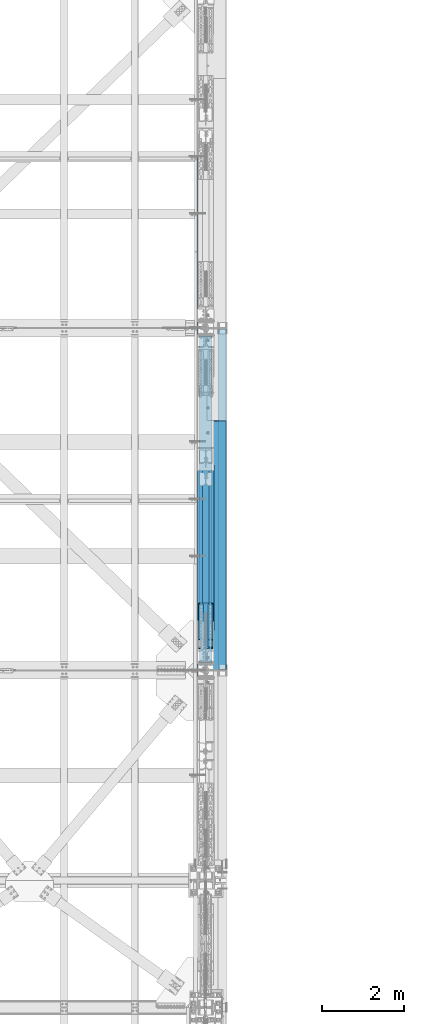
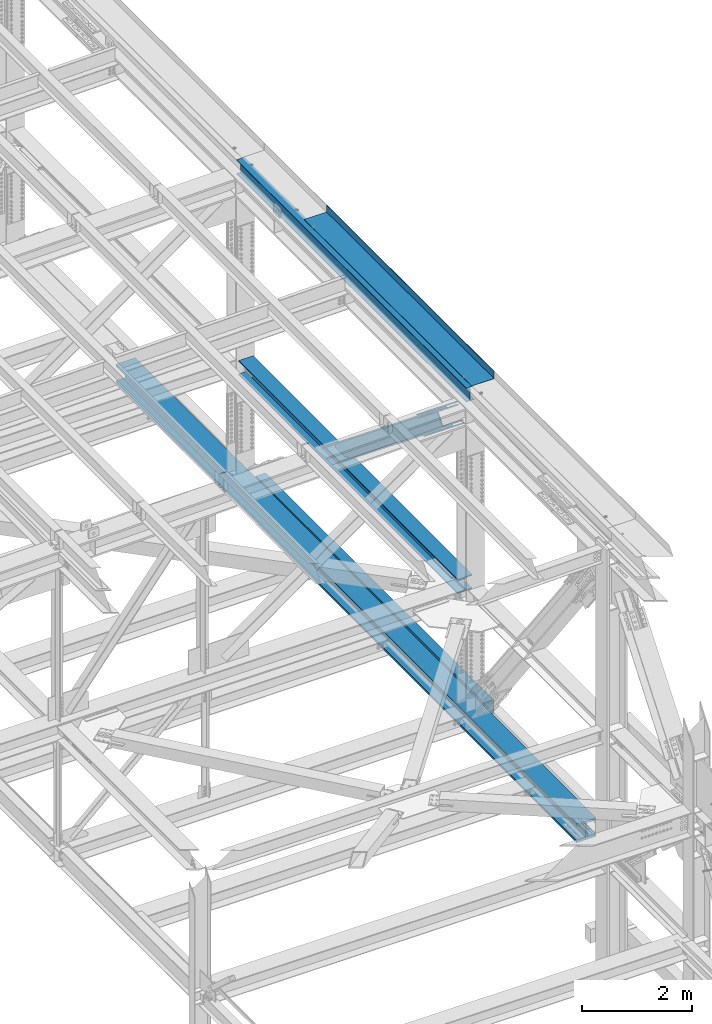
# One storey, part 1962 of 3843: 6 members, 5 beams, 6 elements without a shape of their own.
"""IFC2X3 building model written with IfcOpenShell, lengths in millimetres."""

from ifc_helpers import new_model, si_unit, frame, origin_with_axes, place, context, subcontext, project, spatial, faceted_brep, material, type_object, element, aggregate, save


model = new_model("IFC2X3")

# Units and contexts
model_context = context("Model", 3, precision=1e-05, world=origin_with_axes())
body_context = subcontext(model_context, "Body", "Model", "MODEL_VIEW")
ifc_project = project(units=[si_unit("LENGTHUNIT", "METRE", prefix="MILLI"), si_unit("AREAUNIT", "SQUARE_METRE"), si_unit("VOLUMEUNIT", "CUBIC_METRE"), si_unit("MASSUNIT", "GRAM", prefix="KILO"), si_unit("TIMEUNIT", "SECOND"), si_unit("PLANEANGLEUNIT", "RADIAN"), si_unit("SOLIDANGLEUNIT", "STERADIAN"), si_unit("THERMODYNAMICTEMPERATUREUNIT", "DEGREE_CELSIUS"), si_unit("LUMINOUSINTENSITYUNIT", "LUMEN")], contexts=[model_context])

# Site, building, storey
site_placement = place(None, origin_with_axes())
site = spatial("IfcSite", under=ifc_project, at=site_placement, CompositionType="ELEMENT")
building_placement = place(site_placement, origin_with_axes())
building = spatial("IfcBuilding", under=site, at=building_placement, Name="Undefined", CompositionType="ELEMENT")
storey_placement = place(building_placement, origin_with_axes())
storey = spatial("IfcBuildingStorey", under=building, at=storey_placement, Name="Undefined", CompositionType="ELEMENT", Elevation=0.0)

# Assembly, beam
assembly_1_placement = place(storey_placement, origin_with_axes())
assembly_1 = element("IfcElementAssembly", 1, at=assembly_1_placement, inside=storey, Name="BEAM", AssemblyPlace="NOTDEFINED", PredefinedType="RIGID_FRAME")
ifc_material_1 = material(Name="STEEL/A992")
beam_type_1 = type_object("IfcBeamType", Name="W12X26", PredefinedType="NOTDEFINED")
beam_1_placement = place(assembly_1_placement, frame((85648.8000000008, 33845.5, 46612.1749999998), z_axis=(0.0, 0.0, 1.0), x_axis=(0.0, 1.0, 0.0)))
beam_1 = element("IfcBeam", 2, at=beam_1_placement, type_object=beam_type_1, material=ifc_material_1, Name="BEAM", ObjectType="W12X26", context=body_context, shape_type="Brep", body=[
    faceted_brep([(0.0, 82.5500000000029, -155.574999999997), (0.0, 82.5500000000029, -146.050000000003), (8356.60000000001, 82.5500000000029, -146.050000000003), (8356.60000000001, 82.5500000000029, -155.574999999997), (0.0, 3.17500000000291, -146.050000000003), (8356.60000000001, 3.17500000000291, -146.050000000003), (0.0, 3.17500000000291, 146.050000000003), (8356.60000000001, 3.17500000000291, 146.050000000003), (0.0, 82.5500000000029, 146.050000000003), (8356.60000000001, 82.5500000000029, 146.050000000003), (0.0, 82.5500000000029, 155.574999999997), (8356.60000000001, 82.5500000000029, 155.574999999997), (0.0, -82.5500000000029, 155.574999999997), (8356.60000000001, -82.5500000000029, 155.574999999997), (0.0, -82.5500000000029, 146.050000000003), (8356.60000000001, -82.5500000000029, 146.050000000003), (0.0, -3.17500000000291, 146.050000000003), (8356.60000000001, -3.17500000000291, 146.050000000003), (0.0, -3.17500000000291, -146.050000000003), (8356.60000000001, -3.17500000000291, -146.050000000003), (0.0, -82.5500000000029, -146.050000000003), (8356.60000000001, -82.5500000000029, -146.050000000003), (0.0, -82.5500000000029, -155.574999999997), (8356.60000000001, -82.5500000000029, -155.574999999997)], [[[0, 1, 2, 3]], [[1, 4, 5, 2]], [[4, 6, 7, 5]], [[6, 8, 9, 7]], [[8, 10, 11, 9]], [[10, 12, 13, 11]], [[12, 14, 15, 13]], [[14, 16, 17, 15]], [[16, 18, 19, 17]], [[18, 20, 21, 19]], [[20, 22, 23, 21]], [[22, 0, 3, 23]], [[5, 7, 9, 11, 13, 15, 17, 19, 21, 23, 3, 2]], [[22, 20, 18, 16, 14, 12, 10, 8, 6, 4, 1, 0]]]),
])

assembly_2_placement = place(storey_placement, origin_with_axes())
assembly_2 = element("IfcElementAssembly", 3, at=assembly_2_placement, inside=storey, Name="BEAM", AssemblyPlace="NOTDEFINED", PredefinedType="RIGID_FRAME")
ifc_material_2 = material()
beam_type_2 = type_object("IfcBeamType", Name="HSS12X8X3/8", PredefinedType="NOTDEFINED")
beam_2_placement = place(assembly_2_placement, frame((86055.2000000001, 42176.7, 39477.9500002714), z_axis=(0.0, 0.0, 1.0), x_axis=(0.0, -1.0, 0.0)))
beam_2 = element("IfcBeam", 4, at=beam_2_placement, type_object=beam_type_2, material=ifc_material_2, Name="BEAM", ObjectType="HSS12X8X3/8", context=body_context, shape_type="Brep", body=[
    faceted_brep([(0.0, 92.0749999999971, -142.875), (0.0, -92.0749999999971, -142.875), (8305.80000000002, -92.0749999999971, -142.875), (8305.80000000002, 92.0749999999971, -142.875), (0.0, -92.0749999999971, 142.875), (8305.80000000002, -92.0749999999971, 142.875), (0.0, 92.0749999999971, 142.875), (8305.80000000002, 92.0749999999971, 142.875), (0.0, 101.600000000006, -152.400000000001), (0.0, 101.600000000006, 152.400000000001), (8305.80000000002, 101.600000000006, 152.400000000001), (8305.80000000002, 101.600000000006, -152.400000000001), (0.0, -101.600000000006, 152.400000000001), (8305.80000000002, -101.600000000006, 152.400000000001), (0.0, -101.600000000006, -152.400000000001), (8305.80000000002, -101.600000000006, -152.400000000001)], [[[0, 1, 2, 3]], [[1, 4, 5, 2]], [[4, 6, 7, 5]], [[6, 0, 3, 7]], [[8, 9, 10, 11]], [[9, 12, 13, 10]], [[12, 14, 15, 13]], [[14, 8, 11, 15]], [[13, 15, 11, 10], [5, 7, 3, 2]], [[14, 12, 9, 8], [6, 4, 1, 0]]]),
])
aggregate(assembly_2, [beam_2])

assembly_3_placement = place(storey_placement, origin_with_axes())
assembly_3 = element("IfcElementAssembly", 5, at=assembly_3_placement, inside=storey, Name="BEAM", AssemblyPlace="NOTDEFINED", PredefinedType="RIGID_FRAME")
beam_type_3 = type_object("IfcBeamType", Name="W14X257", PredefinedType="NOTDEFINED")
beam_3_placement = place(assembly_3_placement, frame((85648.8, 29630.1176465666, 39480.9143759038), z_axis=(0.0, -0.00349395200045545, 0.999993896131081), x_axis=(0.0, 0.999993896131081, 0.00349395200045545)))
beam_3 = element("IfcBeam", 6, at=beam_3_placement, type_object=beam_type_3, material=ifc_material_1, Name="BEAM", ObjectType="W14X257", context=body_context, shape_type="Brep", body=[
    faceted_brep([(13400.7918144194, -203.199999999997, 164.088281632765), (13400.7918144194, -15.0812500000029, 164.088281632765), (15075.9184465029, -15.0812500000029, 162.447245856085), (15075.9184465029, -203.199999999997, 162.447245856085), (11725.6647886285, -203.199999999997, 165.26045013847), (11725.6647886285, -15.0812500000029, 165.26045013847), (10050.537500366, -203.199999999997, 165.963751280062), (10050.537500366, -15.0812500000029, 165.963751280062), (8375.41008086779, -203.199999999997, 166.198185003552), (8375.41008086779, -15.0812500000029, 166.198185003552), (6700.28266136955, -203.199999999997, 165.963751289346), (6700.28266136955, -15.0812500000029, 165.963751289346), (5025.1553731071, -203.199999999997, 165.260450157024), (5025.1553731071, -15.0812500000029, 165.260450157024), (3350.02834731621, -203.199999999997, 164.088281660603), (3350.02834731621, -15.0812500000029, 164.088281660603), (1674.90171523266, -203.199999999997, 162.447245893207), (1674.90171523266, -15.0812500000029, 162.447245893207), (6.12560524529545, -203.199999999997, 160.345341113098), (6.12560524529545, -15.0812500000029, 160.345341113098), (13400.7918144194, 15.0812500000029, 164.088281632765), (13400.7918144194, 203.199999999997, 164.088281632765), (15075.9184465029, 203.199999999997, 162.447245856085), (15075.9184465029, 15.0812500000029, 162.447245856085), (11725.6647886285, 15.0812500000029, 165.26045013847), (11725.6647886285, 203.199999999997, 165.26045013847), (10050.537500366, 15.0812500000029, 165.963751280062), (10050.537500366, 203.199999999997, 165.963751280062), (8375.41008086779, 15.0812500000029, 166.198185003552), (8375.41008086779, 203.199999999997, 166.198185003552), (6700.28266136955, 15.0812500000029, 165.963751289346), (6700.28266136955, 203.199999999997, 165.963751289346), (5025.1553731071, 15.0812500000029, 165.260450157024), (5025.1553731071, 203.199999999997, 165.260450157024), (3350.02834731621, 15.0812500000029, 164.088281660603), (3350.02834731621, 203.199999999997, 164.088281660603), (1674.90171523266, 15.0812500000029, 162.447245893207), (1674.90171523266, 203.199999999997, 162.447245893207), (6.12560524529545, 15.0812500000029, 160.345341113098), (6.12560524529545, 203.199999999997, 160.345341113098), (13400.5225440723, 203.199999999997, -156.586605315169), (13400.5225440723, 15.0812500000029, -156.586605315169), (15075.5594194066, 15.0812500000029, -158.227553161756), (15075.5594194066, 203.199999999997, -158.227553161756), (11725.4852750518, 203.199999999997, -155.41449961668), (11725.4852750518, 15.0812500000029, -155.41449961668), (10050.4477435737, 203.199999999997, -154.711236159405), (10050.4477435737, 15.0812500000029, -154.711236159405), (8375.4100808669, 203.199999999997, -154.476814997368), (8375.4100808669, 15.0812500000029, -154.476814997368), (6700.37241816011, 203.199999999997, -154.71123615012), (6700.37241816011, 15.0812500000029, -154.71123615012), (5025.33488668206, 203.199999999997, -155.414499598119), (5025.33488668206, 15.0812500000029, -155.414499598119), (3350.29761766152, 203.199999999997, -156.586605287324), (3350.29761766152, 15.0812500000029, -156.586605287324), (1675.26074232721, 203.199999999997, -158.227553124634), (1675.26074232721, 15.0812500000029, -158.227553124634), (6.57438513686066, 203.199999999997, -160.329344856727), (6.57438513686066, 15.0812500000029, -160.329344856727), (13400.4825534267, -203.199999999997, -204.211588525264), (13400.4825534267, 203.199999999997, -204.211588525264), (15075.5060985507, 203.199999999997, -205.852523312911), (15075.5060985507, -203.199999999997, -205.852523312911), (11725.4586146196, -203.199999999997, -203.039492154574), (11725.4586146196, 203.199999999997, -203.039492154574), (10050.434413357, -203.199999999997, -202.336234293987), (10050.434413357, 203.199999999997, -202.336234293987), (8375.41008086677, -203.199999999997, -202.101814997499), (8375.41008086677, 203.199999999997, -202.101814997499), (6700.38574837653, -203.199999999997, -202.336234284703), (6700.38574837653, 203.199999999997, -202.336234284703), (5025.36154711401, -203.199999999997, -203.039492136013), (5025.36154711401, 203.199999999997, -203.039492136013), (3350.33760830687, -203.199999999997, -204.211588497419), (3350.33760830687, 203.199999999997, -204.211588497419), (1675.31406318286, -203.199999999997, -205.852523275797), (1675.31406318286, 203.199999999997, -205.852523275797), (6.64103561578668, -203.199999999997, -207.954298218574), (6.64103561578668, 203.199999999997, -207.954298218574), (13400.5225440723, -15.0812500000029, -156.586605315169), (13400.5225440723, -203.199999999997, -156.586605315169), (15075.5594194066, -203.199999999997, -158.227553161756), (15075.5594194066, -15.0812500000029, -158.227553161756), (11725.4852750518, -15.0812500000029, -155.41449961668), (11725.4852750518, -203.199999999997, -155.41449961668), (10050.4477435737, -15.0812500000029, -154.711236159405), (10050.4477435737, -203.199999999997, -154.711236159405), (8375.4100808669, -15.0812500000029, -154.476814997368), (8375.4100808669, -203.199999999997, -154.476814997368), (6700.37241816011, -15.0812500000029, -154.71123615012), (6700.37241816011, -203.199999999997, -154.71123615012), (5025.33488668206, -15.0812500000029, -155.414499598119), (5025.33488668206, -203.199999999997, -155.414499598119), (3350.29761766152, -15.0812500000029, -156.586605287324), (3350.29761766152, -203.199999999997, -156.586605287324), (1675.26074232721, -15.0812500000029, -158.227553124634), (1675.26074232721, -203.199999999997, -158.227553124634), (6.57438513686066, -15.0812500000029, -160.329344856727), (6.57438513686066, -203.199999999997, -160.329344856727), (6.05895476636942, -203.199999999997, 207.970294474952), (6.05895476636942, 203.199999999997, 207.970294474952), (1674.84839437701, -203.199999999997, 210.072216044369), (1674.84839437701, 203.199999999997, 210.072216044369), (3349.98835667086, -203.199999999997, 211.71326487069), (3349.98835667086, 203.199999999997, 211.71326487069), (5025.12871267518, -203.199999999997, 212.885442694918), (5025.12871267518, 203.199999999997, 212.885442694918), (6700.26933115313, -203.199999999997, 213.588749423921), (6700.26933115313, 203.199999999997, 213.588749423921), (8375.41008086794, -203.199999999997, 213.823185003683), (8375.41008086794, 203.199999999997, 213.823185003683), (10050.5508305827, -203.199999999997, 213.588749414637), (10050.5508305827, 203.199999999997, 213.588749414637), (11725.6914490607, -203.199999999997, 212.88544267635), (11725.6914490607, 203.199999999997, 212.88544267635), (13400.831805065, -203.199999999997, 211.713264842845), (13400.831805065, 203.199999999997, 211.713264842845), (15075.9717673588, -203.199999999997, 210.072216007247), (15075.9717673588, 203.199999999997, 210.072216007247), (16744.7612150182, -203.199999999997, 207.970294418446), (16744.7612150182, 203.199999999997, 207.970294418446), (16744.6945213029, 203.199999999997, 160.345341111053), (16744.6945213029, 15.0812500000029, 160.345341111053), (16744.2457755613, 15.0812500000029, -160.329344906248), (16744.2457755613, 203.199999999997, -160.329344906248), (16744.1791242729, 203.199999999997, -207.954298267068), (16744.1791242729, -203.199999999997, -207.954298267068), (16744.2457755613, -203.199999999997, -160.329344906248), (16744.2457755613, -15.0812500000029, -160.329344906248), (16744.6945213029, -15.0812500000029, 160.345341111053), (16744.6945213029, -203.199999999997, 160.345341111053)], [[[0, 1, 2, 3]], [[4, 5, 1, 0]], [[6, 7, 5, 4]], [[8, 9, 7, 6]], [[10, 11, 9, 8]], [[12, 13, 11, 10]], [[14, 15, 13, 12]], [[16, 17, 15, 14]], [[17, 16, 18, 19]], [[20, 21, 22, 23]], [[24, 25, 21, 20]], [[26, 27, 25, 24]], [[28, 29, 27, 26]], [[30, 31, 29, 28]], [[32, 33, 31, 30]], [[34, 35, 33, 32]], [[36, 37, 35, 34]], [[37, 36, 38, 39]], [[40, 41, 42, 43]], [[44, 45, 41, 40]], [[46, 47, 45, 44]], [[48, 49, 47, 46]], [[50, 51, 49, 48]], [[52, 53, 51, 50]], [[54, 55, 53, 52]], [[56, 57, 55, 54]], [[57, 56, 58, 59]], [[60, 61, 62, 63]], [[64, 65, 61, 60]], [[66, 67, 65, 64]], [[68, 69, 67, 66]], [[70, 71, 69, 68]], [[72, 73, 71, 70]], [[74, 75, 73, 72]], [[76, 77, 75, 74]], [[77, 76, 78, 79]], [[80, 81, 82, 83]], [[84, 85, 81, 80]], [[86, 87, 85, 84]], [[88, 89, 87, 86]], [[90, 91, 89, 88]], [[92, 93, 91, 90]], [[94, 95, 93, 92]], [[96, 97, 95, 94]], [[97, 96, 98, 99]], [[19, 18, 100, 101, 39, 38, 59, 58, 79, 78, 99, 98]], [[102, 103, 101, 100]], [[103, 102, 104, 105]], [[105, 104, 106, 107]], [[107, 106, 108, 109]], [[109, 108, 110, 111]], [[111, 110, 112, 113]], [[113, 112, 114, 115]], [[115, 114, 116, 117]], [[117, 116, 118, 119]], [[119, 118, 120, 121]], [[22, 21, 25, 27, 29, 31, 33, 35, 37, 39, 101, 103, 105, 107, 109, 111, 113, 115, 117, 119, 121, 122]], [[23, 22, 122, 123]], [[42, 41, 45, 47, 49, 51, 53, 55, 57, 59, 38, 36, 34, 32, 30, 28, 26, 24, 20, 23, 123, 124]], [[43, 42, 124, 125]], [[62, 61, 65, 67, 69, 71, 73, 75, 77, 79, 58, 56, 54, 52, 50, 48, 46, 44, 40, 43, 125, 126]], [[63, 62, 126, 127]], [[82, 81, 85, 87, 89, 91, 93, 95, 97, 99, 78, 76, 74, 72, 70, 68, 66, 64, 60, 63, 127, 128]], [[83, 82, 128, 129]], [[2, 1, 5, 7, 9, 11, 13, 15, 17, 19, 98, 96, 94, 92, 90, 88, 86, 84, 80, 83, 129, 130]], [[3, 2, 130, 131]], [[118, 116, 114, 112, 110, 108, 106, 104, 102, 100, 18, 16, 14, 12, 10, 8, 6, 4, 0, 3, 131, 120]], [[130, 129, 128, 127, 126, 125, 124, 123, 122, 121, 120, 131]]]),
])
aggregate(assembly_3, [beam_3])

# Assembly, members
assembly_4_placement = place(storey_placement, origin_with_axes())
assembly_4 = element("IfcElementAssembly", 7, at=assembly_4_placement, inside=storey, Name="BEAM", AssemblyPlace="NOTDEFINED", PredefinedType="RIGID_FRAME")
ifc_material_3 = material(Name="STEEL/A572-50")
member_type_1 = type_object("IfcMemberType", PredefinedType="NOTDEFINED")
member_1_placement = place(assembly_4_placement, frame((85534.5, 35452.9021999179, 45164.9695957587), z_axis=(1.0, 0.0, 0.0), x_axis=(0.0, -0.778233356227861, 0.62797519318387)))
member_1 = element("IfcMember", 8, at=member_1_placement, type_object=member_type_1, material=ifc_material_3, Name="PLATE", context=body_context, shape_type="Brep", body=[
    faceted_brep([(-4.36557456851006e-11, 12.7000000000116, -63.5), (-4.36557456851006e-11, 12.7000000000116, 63.5), (1104.90000001677, 12.7000000017251, 63.5), (1104.90000001677, 12.7000000017251, -63.5), (1.45519152283669e-11, -12.700000000008, 63.5), (1104.90000001682, -12.6999999982909, 63.5), (1.45519152283669e-11, -12.700000000008, -63.5), (1104.90000001682, -12.6999999982909, -63.5)], [[[0, 1, 2, 3]], [[1, 4, 5, 2]], [[4, 6, 7, 5]], [[6, 0, 3, 7]], [[5, 7, 3, 2]], [[6, 4, 1, 0]]]),
])
member_2_placement = place(assembly_4_placement, frame((85763.1, 35267.4768249211, 44935.1767414138), z_axis=(1.0, 0.0, 0.0), x_axis=(0.0, -0.778233356227861, 0.62797519318387)))
member_2 = element("IfcMember", 9, at=member_2_placement, type_object=member_type_1, material=ifc_material_3, Name="PLATE", context=body_context, shape_type="Brep", body=[
    faceted_brep([(-4.36557456851006e-11, 12.7000000000116, -63.5), (-4.36557456851006e-11, 12.7000000000116, 63.5), (1104.90000001677, 12.7000000017251, 63.5), (1104.90000001677, 12.7000000017251, -63.5), (1.45519152283669e-11, -12.700000000008, 63.5), (1104.90000001682, -12.6999999982909, 63.5), (1.45519152283669e-11, -12.700000000008, -63.5), (1104.90000001682, -12.6999999982909, -63.5)], [[[0, 1, 2, 3]], [[1, 4, 5, 2]], [[4, 6, 7, 5]], [[6, 0, 3, 7]], [[5, 7, 3, 2]], [[6, 4, 1, 0]]]),
])
member_3_placement = place(assembly_4_placement, frame((85763.1, 35452.9021999179, 45164.9695957587), z_axis=(1.0, 0.0, 0.0), x_axis=(0.0, -0.778233356227861, 0.62797519318387)))
member_3 = element("IfcMember", 10, at=member_3_placement, type_object=member_type_1, material=ifc_material_3, Name="PLATE", context=body_context, shape_type="Brep", body=[
    faceted_brep([(-4.36557456851006e-11, 12.7000000000116, -63.5), (-4.36557456851006e-11, 12.7000000000116, 63.5), (1104.90000001677, 12.7000000017251, 63.5), (1104.90000001677, 12.7000000017251, -63.5), (1.45519152283669e-11, -12.700000000008, 63.5), (1104.90000001682, -12.6999999982909, 63.5), (1.45519152283669e-11, -12.700000000008, -63.5), (1104.90000001682, -12.6999999982909, -63.5)], [[[0, 1, 2, 3]], [[1, 4, 5, 2]], [[4, 6, 7, 5]], [[6, 0, 3, 7]], [[5, 7, 3, 2]], [[6, 4, 1, 0]]]),
])
member_type_2 = type_object("IfcMemberType", PredefinedType="NOTDEFINED")
member_4_placement = place(assembly_4_placement, frame((85648.8, 34372.7149158555, 45585.7859388178), z_axis=(1.0, 0.0, 0.0), x_axis=(0.0, 0.778233356227861, -0.62797519318387)))
member_4 = element("IfcMember", 11, at=member_4_placement, type_object=member_type_2, material=ifc_material_3, Name="PLATE", context=body_context, shape_type="Brep", body=[
    faceted_brep([(-1.45519152283669e-11, 12.7000000000025, -177.800000000003), (-1.45519152283669e-11, 12.7000000000025, 177.800000000003), (1104.90000001682, 12.7000000017051, 177.800000000003), (1104.90000001682, 12.7000000017051, -177.800000000003), (4.36557456851006e-11, -12.7000000000171, 177.800000000003), (1104.90000001686, -12.6999999983072, 177.800000000003), (4.36557456851006e-11, -12.7000000000171, -177.800000000003), (1104.90000001686, -12.6999999983072, -177.800000000003)], [[[0, 1, 2, 3]], [[1, 4, 5, 2]], [[4, 6, 7, 5]], [[6, 0, 3, 7]], [[5, 7, 3, 2]], [[6, 4, 1, 0]]]),
])
member_5_placement = place(assembly_4_placement, frame((85648.8, 34627.9240360836, 45902.0599773256), z_axis=(1.0, 0.0, 0.0), x_axis=(0.0, 0.778233356227861, -0.62797519318387)))
member_5 = element("IfcMember", 12, at=member_5_placement, type_object=member_type_2, material=ifc_material_3, Name="PLATE", context=body_context, shape_type="Brep", body=[
    faceted_brep([(-1.45519152283669e-11, 12.7000000000025, -177.800000000003), (-1.45519152283669e-11, 12.7000000000025, 177.800000000003), (1104.90000001682, 12.7000000017051, 177.800000000003), (1104.90000001682, 12.7000000017051, -177.800000000003), (4.36557456851006e-11, -12.7000000000171, 177.800000000003), (1104.90000001686, -12.6999999983072, 177.800000000003), (4.36557456851006e-11, -12.7000000000171, -177.800000000003), (1104.90000001686, -12.6999999983072, -177.800000000003)], [[[0, 1, 2, 3]], [[1, 4, 5, 2]], [[4, 6, 7, 5]], [[6, 0, 3, 7]], [[5, 7, 3, 2]], [[6, 4, 1, 0]]]),
])
aggregate(assembly_4, [member_1, member_2, member_3, member_4, member_5])

# Assembly, member
assembly_5_placement = place(storey_placement, origin_with_axes())
assembly_5 = element("IfcElementAssembly", 13, at=assembly_5_placement, inside=storey, Name="V. BRACE", AssemblyPlace="NOTDEFINED", PredefinedType="RIGID_FRAME")
member_type_3 = type_object("IfcMemberType", Name="W14X159", PredefinedType="NOTDEFINED")
member_6_placement = place(assembly_5_placement, frame((85648.8, 38783.8019862773, 42287.4780071434), z_axis=(0.0, 0.627975193183871, 0.77823335622786), x_axis=(0.0, -0.778233356227861, 0.62797519318387)))
member_6 = element("IfcMember", 14, at=member_6_placement, type_object=member_type_3, material=ifc_material_1, Name="V. BRACE", ObjectType="W14X159", context=body_context, shape_type="Brep", body=[
    faceted_brep([(59.6425216840507, -198.4375, 190.500000000553), (59.6425216840507, 198.4375, 190.500000000553), (59.5305987764768, 198.4375, 160.337500000489), (59.5305987764768, 9.52499999999418, 160.337500000489), (59.5305987764768, -9.52499999999418, 160.337500000489), (59.5305987764768, -198.4375, 160.337500000489), (532.266705060934, 9.52499999999418, -122.702002043785), (532.266705060934, -9.52499999999418, -122.702002043785), (437.250171938289, -9.52500015769328, -122.619090698638), (407.045025164269, 9.52499999999418, -122.592733713522), (535.911130543864, 9.52499999999418, -123.430229865684), (535.911130543864, -9.52499999999418, -123.430229865684), (538.999459933144, 9.52499999999418, -125.497685897761), (538.999459933144, -9.52499999999418, -125.497685897761), (541.061523075339, 9.52499999999418, -128.589618700833), (541.061523075339, -9.52499999999418, -128.589618700833), (541.783389549921, 9.52499999999418, -132.235309534415), (541.783389549921, -9.52499999999418, -132.235309534415), (4945.31065606197, 9.52499999999418, -160.337499989153), (4945.31065606197, 198.4375, -160.337499989153), (541.758867617384, 198.4375, -160.337499999128), (541.758867617384, 9.52499999999418, -160.337499999128), (541.758455053583, -198.4375, -160.810299044431), (541.758455053583, 198.4375, -160.810299044431), (491.006047097799, 198.4375, -160.766012257423), (491.006047097799, -198.4375, -160.766012257423), (490.980101196303, 198.4375, -190.499999999309), (490.980101196303, -198.4375, -190.499999999309), (4945.31065604303, 198.4375, -190.499999989232), (4945.31065604303, -198.4375, -190.499999989232), (4945.31065606197, -198.4375, -160.337499989153), (541.758867617384, -198.4375, -160.337499999128), (4945.31065606197, -9.52499999999418, -160.337499989153), (541.758867617384, -9.52499999999418, -160.337499999128), (4945.31065626335, 9.52499999999418, 160.337500011548), (4945.31065626335, 198.4375, 160.337500011548), (4945.31065628229, 198.4375, 190.500000011612), (4945.31065628229, -198.4375, 190.500000011612), (4945.31065626335, -198.4375, 160.337500011548), (4945.31065626335, -9.52499999999418, 160.337500011548), (60.8213226999287, -9.52499999999418, 159.286652054056), (145.916054320041, -9.52499999999418, 159.212398994998), (172.123502483912, -9.52499999999418, 138.027193878013), (175.301859875894, -9.52499999999418, 133.209107061186), (175.114208263778, -9.52499999999418, 127.44016407671), (171.62945635886, -9.52499999999418, 122.83881422619), (166.127261502032, -9.52499999999418, 121.094747701325), (137.873665474275, -9.52499999999418, 121.119401750053), (60.8213226999287, 9.52499999999418, 159.286652054056), (145.916054320041, 9.52499999999418, 159.212398994998), (172.123502483912, 9.52499999999418, 138.027193878013), (175.301859875894, 9.52499999999418, 133.209107061186), (175.114208263778, 9.52499999999418, 127.44016407671), (171.62945635886, 9.52499999999418, 122.83881422619), (166.127261502032, 9.52499999999418, 121.094747701325), (107.668598508451, 9.52499999999418, 121.145758649596)], [[[0, 1, 2, 3, 4, 5]], [[6, 7, 8, 9]], [[7, 6, 10, 11]], [[11, 10, 12, 13]], [[13, 12, 14, 15]], [[15, 14, 16, 17]], [[18, 19, 20, 21]], [[22, 23, 24, 25]], [[26, 27, 25, 24]], [[28, 29, 27, 26]], [[25, 27, 29, 30, 31, 22]], [[30, 32, 33, 31]], [[17, 16, 21, 20, 23, 22, 31, 33]], [[19, 28, 26, 24, 23, 20]], [[18, 34, 35, 36, 37, 38, 39, 32, 30, 29, 28, 19]], [[38, 37, 0, 5]], [[39, 38, 5, 4]], [[7, 11, 13, 15, 17, 33, 32, 39, 4, 40, 41, 42, 43, 44, 45, 46, 47, 8]], [[48, 40, 4, 3]], [[40, 48, 49, 41]], [[41, 49, 50, 42]], [[42, 50, 51, 43]], [[43, 51, 52, 44]], [[44, 52, 53, 45]], [[45, 53, 54, 46]], [[46, 54, 55, 47]], [[8, 47, 55, 9]], [[54, 53, 52, 51, 50, 49, 48, 3, 34, 18, 21, 16, 14, 12, 10, 6, 9, 55]], [[35, 34, 3, 2]], [[36, 35, 2, 1]], [[37, 36, 1, 0]]]),
])
aggregate(assembly_5, [member_6])

# Assembly, beam
assembly_6_placement = place(storey_placement, origin_with_axes())
assembly_6 = element("IfcElementAssembly", 15, at=assembly_6_placement, inside=storey, Name="BEAM", AssemblyPlace="NOTDEFINED", PredefinedType="RIGID_FRAME")
beam_type_4 = type_object("IfcBeamType", Name="W12X87", PredefinedType="NOTDEFINED")
beam_4_placement = place(assembly_6_placement, frame((85648.8, 33845.1829832804, 42270.2385812093), z_axis=(0.0, -0.00349071700149943, 0.999993907428848), x_axis=(0.0, 0.999993907428848, 0.00349071700149724)))
beam_4 = element("IfcBeam", 16, at=beam_4_placement, type_object=beam_type_4, material=ifc_material_1, Name="BEAM", ObjectType="W12X87", context=body_context, shape_type="Brep", body=[
    faceted_brep([(198.201572935061, -153.987500000003, -158.749999998894), (198.201572935061, 153.987500000003, -158.749999998894), (8157.97506839022, 153.987500000003, -158.749999972904), (8157.97506839022, -153.987500000003, -158.749999972904), (198.273613046091, -153.987500000003, -138.112499998948), (198.273613046091, -6.35000000000582, -138.112499998948), (199.237842224458, -6.35000000000582, 138.112500000258), (199.237842224458, -153.987500000003, 138.112500000258), (199.309882335489, -153.987500000003, 158.750000000204), (199.309882335489, 153.987500000003, 158.750000000204), (199.237842224458, 153.987500000003, 138.112500000258), (199.237842224458, 6.35000000000582, 138.112500000258), (198.273613046091, 6.35000000000582, -138.112499998948), (198.273613046091, 153.987500000003, -138.112499998948), (8158.04710850125, -153.987500000003, -138.112499972958), (8158.04710850125, -6.35000000000582, -138.112499972958), (8159.01133767962, -6.35000000000582, 138.112500026247), (8159.01133767962, -153.987500000003, 138.112500026247), (8159.08337779065, -153.987500000003, 158.750000026193), (8159.08337779065, 153.987500000003, 158.750000026193), (8159.01133767962, 153.987500000003, 138.112500026247), (8159.01133767962, 6.35000000000582, 138.112500026247), (8158.04710850125, 6.35000000000582, -138.112499972958), (8158.04710850125, 153.987500000003, -138.112499972958)], [[[0, 1, 2, 3]], [[0, 4, 5, 6, 7, 8, 9, 10, 11, 12, 13, 1]], [[5, 4, 14, 15]], [[6, 5, 15, 16]], [[7, 6, 16, 17]], [[8, 7, 17, 18]], [[9, 8, 18, 19]], [[10, 9, 19, 20]], [[11, 10, 20, 21]], [[12, 11, 21, 22]], [[13, 12, 22, 23]], [[1, 13, 23, 2]], [[22, 21, 20, 19, 18, 17, 16, 15, 14, 3, 2, 23]], [[4, 0, 3, 14]]]),
])
aggregate(assembly_6, [beam_4])

# Beam
ifc_material_4 = material(Name="STEEL/A36")
beam_type_5 = type_object("IfcBeamType", PredefinedType="NOTDEFINED")
beam_5_placement = place(assembly_1_placement, frame((85680.5500000008, 36893.5, 46772.5124999998), z_axis=(0.0, -1.0, 0.0), x_axis=(1.0, 0.0, 0.0)))
beam_5 = element("IfcBeam", 17, at=beam_5_placement, type_object=beam_type_5, material=ifc_material_4, Name="BENT_PLATE", context=body_context, shape_type="Brep", body=[
    faceted_brep([(466.724998474107, 4.76249999999709, -3044.82500004767), (469.899999921181, 1.58750004768081, -3048.0), (0.0, 1.58750004768081, -3048.0), (0.0, 4.76249999999709, -3044.82500004768), (466.725000000006, 160.337499999994, -3044.82500004767), (469.900001478221, 160.337499968853, -3048.0), (0.0, 4.76249999999709, 3048.0), (466.724998474107, 4.76249999999709, 3048.0), (0.0, -4.76249999999709, -3048.0), (0.0, -4.76249999999709, 3048.0), (476.249998380677, -4.76249999999709, -3048.0), (476.249998380677, -4.76249999999709, 3048.0), (466.725000000006, 160.337499999994, 3048.0), (476.25, 160.337499906571, 3048.0), (476.25, 160.337499906571, -3048.0)], [[[0, 1, 2, 3]], [[4, 5, 1, 0]], [[6, 7, 0, 3]], [[8, 9, 6, 3, 2]], [[9, 8, 10, 11]], [[7, 12, 4, 0]], [[7, 6, 9, 11, 13, 12]], [[11, 10, 14, 13]], [[5, 14, 10, 8, 2, 1]], [[12, 13, 14, 5, 4]]]),
])

aggregate(assembly_1, [beam_5, beam_1])

save(model, "model.ifc")
